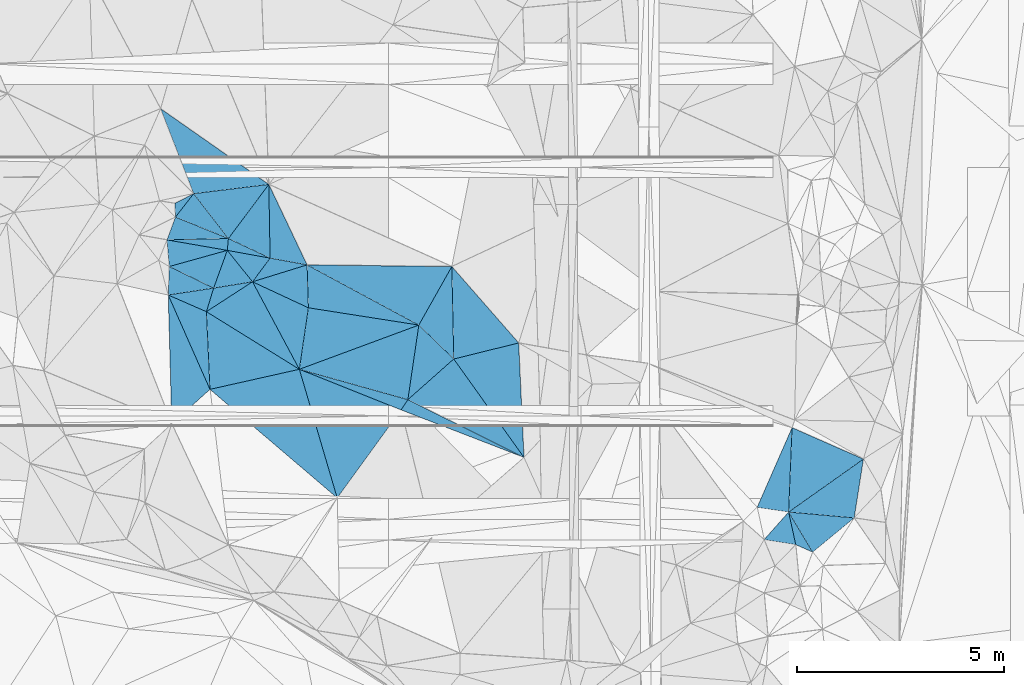
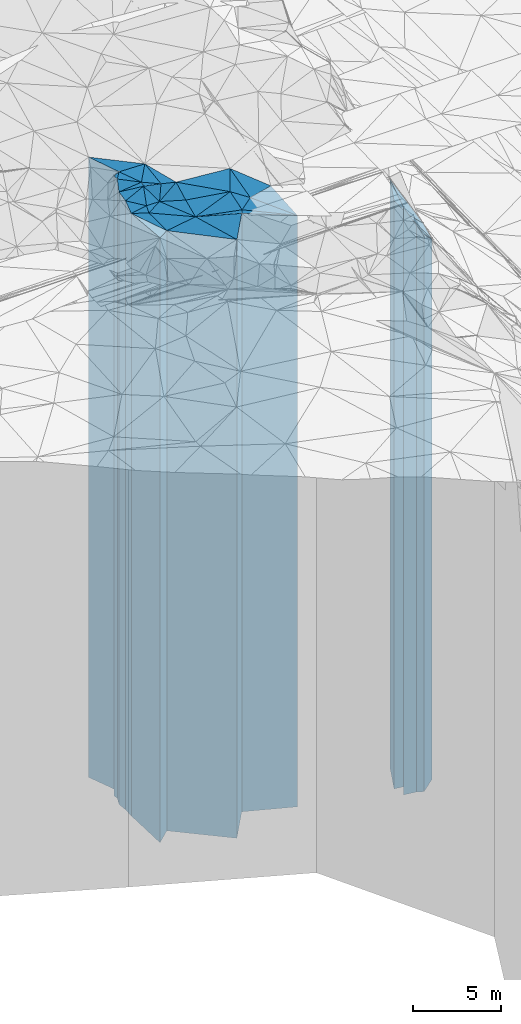
# One storey, part 211 of 275: 42 plates.
"""IFC2X3 building model written with IfcOpenShell, lengths in millimetres."""

from ifc_helpers import new_model, si_unit, frame, origin_with_axes, place, context, subcontext, project, spatial, faceted_brep, material, type_object, element, save


model = new_model("IFC2X3")

# Units and contexts
model_context = context("Model", 3, precision=1e-05, world=origin_with_axes())
body_context = subcontext(model_context, "Body", "Model", "MODEL_VIEW")
ifc_project = project(units=[si_unit("LENGTHUNIT", "METRE", prefix="MILLI"), si_unit("AREAUNIT", "SQUARE_METRE"), si_unit("VOLUMEUNIT", "CUBIC_METRE"), si_unit("MASSUNIT", "GRAM", prefix="KILO"), si_unit("TIMEUNIT", "SECOND"), si_unit("PLANEANGLEUNIT", "RADIAN"), si_unit("SOLIDANGLEUNIT", "STERADIAN"), si_unit("THERMODYNAMICTEMPERATUREUNIT", "DEGREE_CELSIUS"), si_unit("LUMINOUSINTENSITYUNIT", "LUMEN")], contexts=[model_context])

# Site, building, storey
site_placement = place(None, origin_with_axes())
site = spatial("IfcSite", under=ifc_project, at=site_placement, CompositionType="ELEMENT")
building_placement = place(site_placement, origin_with_axes())
building = spatial("IfcBuilding", under=site, at=building_placement, Name="Undefined", CompositionType="ELEMENT")
storey_placement = place(building_placement, origin_with_axes())
storey = spatial("IfcBuildingStorey", under=building, at=storey_placement, Name="Undefined", CompositionType="ELEMENT", Elevation=0.0)

# Plates
ifc_material = material()
plate_type_1 = type_object("IfcPlateType", PredefinedType="NOTDEFINED")
plate_1_placement = place(storey_placement, frame((-114424.275209468, 60931.8089571276, 28524.0), z_axis=(-0.218908902974145, 0.975745300884743, 0.0), x_axis=(0.975745300884743, 0.218908902974141, 0.0)))
element("IfcPlate", 1, at=plate_1_placement, inside=storey, type_object=plate_type_1, material=ifc_material, Name="00", context=body_context, shape_type="Brep", body=[
    faceted_brep([(-5.45696821063757e-12, -20786.0, 0.0), (326.870147705078, -20906.0, 1848.79846191406), (326.870147705078, 20696.0, 1848.79846191406), (0.0, 20696.0, 0.0), (2212.19360351564, -20696.0, 3.82715370506048e-09), (2212.19360351564, 20696.0, 3.82715370506048e-09)], [[[0, 1, 2, 3]], [[1, 4, 5, 2]], [[4, 0, 3, 5]], [[5, 3, 2]], [[4, 1, 0]]]),
])
plate_type_2 = type_object("IfcPlateType", PredefinedType="NOTDEFINED")
plate_2_placement = place(storey_placement, frame((-115431.221927866, 63209.1227928358, 28569.0), z_axis=(0.999623019371744, 0.0274557670102097, 0.0), x_axis=(0.0274557670102113, -0.999623019371743, 0.0)))
element("IfcPlate", 2, at=plate_2_placement, inside=storey, type_object=plate_type_2, material=ifc_material, Name="00", context=body_context, shape_type="Brep", body=[
    faceted_brep([(-1.45519152283669e-11, -20901.0, -1.45519152283669e-11), (2304.10180664061, -20741.0, 944.04174804686), (2304.10180664061, 20741.0, 944.04174804686), (1.45519152283669e-11, 20741.0, -1.45519152283669e-11), (3112.36254882811, -21071.0, -1.28056854009628e-09), (3112.36254882811, 20741.0, -1.28056854009628e-09)], [[[0, 1, 2, 3]], [[1, 4, 5, 2]], [[4, 0, 3, 5]], [[5, 3, 2]], [[4, 1, 0]]]),
])
plate_type_3 = type_object("IfcPlateType", PredefinedType="NOTDEFINED")
plate_3_placement = place(storey_placement, frame((-106841.743380967, 59287.7253005679, 28269.0), z_axis=(-0.814018791273885, -0.580838538195429, 0.0), x_axis=(-0.58083853819543, 0.814018791273885, 0.0)))
element("IfcPlate", 3, at=plate_3_placement, inside=storey, type_object=plate_type_3, material=ifc_material, Name="00", context=body_context, shape_type="Brep", body=[
    faceted_brep([(0.0, -20441.0, 0.0), (2764.37841796875, -20961.0, 1471.83984374999), (2764.37841796875, 20441.0, 1471.83984374999), (2.91038304567337e-11, 20441.0, -1.45519152283669e-11), (2920.22265625, -20821.0, 2.7648638933897e-10), (2920.22265625, 20441.0, 2.7648638933897e-10)], [[[0, 1, 2, 3]], [[1, 4, 5, 2]], [[4, 0, 3, 5]], [[5, 3, 2]], [[4, 1, 0]]]),
])
plate_type_4 = type_object("IfcPlateType", PredefinedType="NOTDEFINED")
plate_4_placement = place(storey_placement, frame((-109645.506137093, 60683.0798817975, 28459.0), z_axis=(-0.663322072844652, 0.748334034824739, 0.0), x_axis=(0.748334034824741, 0.66332207284465, 0.0)))
element("IfcPlate", 4, at=plate_4_placement, inside=storey, type_object=plate_type_4, material=ifc_material, Name="00", context=body_context, shape_type="Brep", body=[
    faceted_brep([(7.27595761418343e-12, -20771.0, 0.0), (1392.30126953125, -20841.0, 1172.17626953125), (1392.30126953125, 20631.0, 1172.17626953125), (7.27595761418343e-12, 20631.0, 0.0), (1480.06762695313, -20631.0, -5.2677933126688e-09), (1480.06762695313, 20631.0, -5.2677933126688e-09)], [[[0, 1, 2, 3]], [[1, 4, 5, 2]], [[4, 0, 3, 5]], [[5, 3, 2]], [[4, 1, 0]]]),
])
plate_type_5 = type_object("IfcPlateType", PredefinedType="NOTDEFINED")
plate_5_placement = place(storey_placement, frame((-111351.75100567, 58310.4171479781, 28519.0), z_axis=(-0.959318896438322, -0.282324733128999, 0.0), x_axis=(-0.282324733128995, 0.959318896438323, 0.0)))
element("IfcPlate", 5, at=plate_5_placement, inside=storey, type_object=plate_type_5, material=ifc_material, Name="00", context=body_context, shape_type="Brep", body=[
    faceted_brep([(0.0, -20691.0, 0.0), (3382.2001953125, -20791.0, 2207.44677734375), (3382.2001953125, 20691.0, 2207.44677734375), (0.0, 20691.0, 0.0), (3237.36010742186, -20701.0, 7.39237293601036e-09), (3237.36010742186, 20691.0, 7.39237293601036e-09)], [[[0, 1, 2, 3]], [[1, 4, 5, 2]], [[4, 0, 3, 5]], [[5, 3, 2]], [[4, 1, 0]]]),
])
plate_type_6 = type_object("IfcPlateType", PredefinedType="NOTDEFINED")
plate_6_placement = place(storey_placement, frame((-108584.435396579, 63896.6649333599, 28459.0), z_axis=(0.871058699947022, -0.491178929970132, 0.0), x_axis=(-0.491178929970129, -0.871058699947024, 0.0)))
element("IfcPlate", 6, at=plate_6_placement, inside=storey, type_object=plate_type_6, material=ifc_material, Name="00", context=body_context, shape_type="Brep", body=[
    faceted_brep([(-1.36424205265939e-11, -21311.0, 1.45519152283669e-11), (1921.20251464842, -20631.0, 1136.74133300783), (1921.20251464842, 20631.0, 1136.74133300783), (7.27595761418343e-12, 20631.0, 0.0), (1622.00488281249, -20841.0, -8.13452061265707e-09), (1622.00488281249, 20631.0, -8.13452061265707e-09)], [[[0, 1, 2, 3]], [[1, 4, 5, 2]], [[4, 0, 3, 5]], [[5, 3, 2]], [[4, 1, 0]]]),
])
plate_type_7 = type_object("IfcPlateType", PredefinedType="NOTDEFINED")
plate_7_placement = place(storey_placement, frame((-112265.737814931, 61416.0778043438, 28509.0), z_axis=(0.370710879079843, 0.928748321200017, 0.0), x_axis=(0.928748321200019, -0.370710879079838, 0.0)))
element("IfcPlate", 7, at=plate_7_placement, inside=storey, type_object=plate_type_7, material=ifc_material, Name="00", context=body_context, shape_type="Brep", body=[
    faceted_brep([(1.45519152283669e-11, -20711.0, 0.0), (2705.26611328124, -20721.0, 290.577789306633), (2705.26611328124, 20681.0, 290.577789306633), (0.0, 20681.0, 0.0), (2644.73071289063, -20681.0, -6.11908035352826e-09), (2644.73071289063, 20681.0, -6.11908035352826e-09)], [[[0, 1, 2, 3]], [[1, 4, 5, 2]], [[4, 0, 3, 5]], [[5, 3, 2]], [[4, 1, 0]]]),
])
plate_type_8 = type_object("IfcPlateType", PredefinedType="NOTDEFINED")
plate_8_placement = place(storey_placement, frame((-115431.221927866, 63209.1227928358, 28629.0), z_axis=(0.399808528152067, 0.916598680348645, 0.0), x_axis=(0.91659867998218, -0.399808528992223, 0.0)))
element("IfcPlate", 8, at=plate_8_placement, inside=storey, type_object=plate_type_8, material=ifc_material, Name="00", context=body_context, shape_type="Brep", body=[
    faceted_brep([(-2.91038304567337e-11, -20841.0, 0.0), (937.52404839384, -20891.0, 591.649108886719), (937.52404839384, 20801.0, 591.649108886719), (-2.91038304567337e-11, 20801.0, 0.0), (1004.98754882813, -20801.0, -5.82076609134674e-11), (1004.98754882813, 20801.0, -5.82076609134674e-11)], [[[0, 1, 2, 3]], [[1, 4, 5, 2]], [[4, 0, 3, 5]], [[5, 3, 2]], [[4, 1, 0]]]),
])
plate_type_9 = type_object("IfcPlateType", PredefinedType="NOTDEFINED")
plate_9_placement = place(storey_placement, frame((-113396.870002641, 63529.141924035, 28609.0), z_axis=(-0.77991973533395, -0.625879546267987, 0.0), x_axis=(-0.625879546267989, 0.779919735333948, 0.0)))
element("IfcPlate", 9, at=plate_9_placement, inside=storey, type_object=plate_type_9, material=ifc_material, Name="00", context=body_context, shape_type="Brep", body=[
    faceted_brep([(0.0, -20781.0, 0.0), (468.398162841782, -20911.0, 827.407470703132), (468.398162841782, 20781.0, 827.407470703132), (0.0, 20781.0, 0.0), (972.676696777358, -21591.0, 1.25874066725373e-09), (972.676696777358, 20781.0, 1.25874066725373e-09)], [[[0, 1, 2, 3]], [[1, 4, 5, 2]], [[4, 0, 3, 5]], [[5, 3, 2]], [[4, 1, 0]]]),
])
plate_type_10 = type_object("IfcPlateType", PredefinedType="NOTDEFINED")
plate_10_placement = place(storey_placement, frame((-108537.92120333, 61664.8413673434, 28459.0), z_axis=(-0.239649905106827, 0.970859373432779, 0.0), x_axis=(0.970859373432779, 0.239649905106829, 0.0)))
element("IfcPlate", 10, at=plate_10_placement, inside=storey, type_object=plate_type_10, material=ifc_material, Name="00", context=body_context, shape_type="Brep", body=[
    faceted_brep([(-1.45519152283669e-11, -20631.0, 1.45519152283669e-11), (489.697570800767, -21311.0, 2177.93383789064), (489.697570800767, 20631.0, 2177.93383789064), (7.27595761418343e-12, 20631.0, 0.0), (1614.46582031249, -20661.0, 1.93540472537279e-09), (1614.46582031249, 20631.0, 1.93540472537279e-09)], [[[0, 1, 2, 3]], [[1, 4, 5, 2]], [[4, 0, 3, 5]], [[5, 3, 2]], [[4, 1, 0]]]),
])
plate_type_11 = type_object("IfcPlateType", PredefinedType="NOTDEFINED")
plate_11_placement = place(storey_placement, frame((-112079.186697475, 63936.8313981279, 28564.0), z_axis=(0.999536862141525, 0.0304312540043118, 0.0), x_axis=(0.0304312540043061, -0.999536862141525, 0.0)))
element("IfcPlate", 11, at=plate_11_placement, inside=storey, type_object=plate_type_11, material=ifc_material, Name="00", context=body_context, shape_type="Brep", body=[
    faceted_brep([(0.0, -21456.0, 0.0), (1534.46032714844, -20736.0, 2652.58959960938), (1534.46032714844, 20736.0, 2652.58959960938), (0.0, 20736.0, 0.0), (1036.19494628906, -20836.0, -1.10594555735588e-09), (1036.19494628906, 20736.0, -1.10594555735588e-09)], [[[0, 1, 2, 3]], [[1, 4, 5, 2]], [[4, 0, 3, 5]], [[5, 3, 2]], [[4, 1, 0]]]),
])
plate_type_12 = type_object("IfcPlateType", PredefinedType="NOTDEFINED")
plate_12_placement = place(storey_placement, frame((-106841.743380967, 59287.7253005679, 28269.0), z_axis=(-0.998916740292856, -0.0465332780136449, 0.0), x_axis=(-0.0465332780136426, 0.998916740292856, 0.0)))
element("IfcPlate", 12, at=plate_12_placement, inside=storey, type_object=plate_type_12, material=ifc_material, Name="00", context=body_context, shape_type="Brep", body=[
    faceted_brep([(0.0, -20441.0, 0.0), (2453.46972656252, -20821.0, 1583.72546386723), (2453.46972656252, 20441.0, 1583.72546386723), (2.91038304567337e-11, 20441.0, -1.45519152283669e-11), (2767.02001953126, -20851.0, -3.08500602841377e-09), (2767.02001953126, 20441.0, -3.08500602841377e-09)], [[[0, 1, 2, 3]], [[1, 4, 5, 2]], [[4, 0, 3, 5]], [[5, 3, 2]], [[4, 1, 0]]]),
])
plate_type_13 = type_object("IfcPlateType", PredefinedType="NOTDEFINED")
plate_13_placement = place(storey_placement, frame((-112079.186697475, 63936.8313981279, 28609.0), z_axis=(-0.179873679992064, -0.983689716956578, 0.0), x_axis=(-0.983689716956578, 0.179873679992061, 0.0)))
element("IfcPlate", 13, at=plate_13_placement, inside=storey, type_object=plate_type_13, material=ifc_material, Name="00", context=body_context, shape_type="Brep", body=[
    faceted_brep([(0.0, -21411.0, -7.27595761418343e-12), (1222.85888671875, -20781.0, 638.056518554695), (1222.85888671875, 20781.0, 638.056518554695), (0.0, 20781.0, 0.0), (906.972961425781, -21511.0, 2.75758793577552e-09), (906.972961425781, 20781.0, 2.75758793577552e-09)], [[[0, 1, 2, 3]], [[1, 4, 5, 2]], [[4, 0, 3, 5]], [[5, 3, 2]], [[4, 1, 0]]]),
])
plate_type_14 = type_object("IfcPlateType", PredefinedType="NOTDEFINED")
plate_14_placement = place(storey_placement, frame((-114335.34226821, 63376.597482125, 28609.0), z_axis=(0.955992514125044, -0.293391058038377, 0.0), x_axis=(-0.293391058038374, -0.955992514125045, 0.0)))
element("IfcPlate", 14, at=plate_14_placement, inside=storey, type_object=plate_type_14, material=ifc_material, Name="00", context=body_context, shape_type="Brep", body=[
    faceted_brep([(-7.27595761418343e-12, -20911.0, 0.0), (-421.170715332039, -20781.0, 852.417297363267), (-421.170715332039, 20781.0, 852.417297363267), (0.0, 20781.0, 0.0), (595.482971191406, -20821.0, -5.82076609134674e-10), (595.482971191406, 20781.0, -5.82076609134674e-10)], [[[0, 1, 2, 3]], [[1, 4, 5, 2]], [[4, 0, 3, 5]], [[5, 3, 2]], [[4, 1, 0]]]),
])
plate_type_15 = type_object("IfcPlateType", PredefinedType="NOTDEFINED")
plate_15_placement = place(storey_placement, frame((-113978.705792529, 64573.0131390828, 28994.0), z_axis=(-0.37506133888815, -0.926999995723532, 0.0), x_axis=(-0.926999995723534, 0.375061338888145, 0.0)))
element("IfcPlate", 15, at=plate_15_placement, inside=storey, type_object=plate_type_15, material=ifc_material, Name="00", context=body_context, shape_type="Brep", body=[
    faceted_brep([(1.45519152283669e-11, -21306.0, 3.63797880709171e-12), (1362.92297363281, -21166.0, 586.720397949215), (1362.92297363281, 21166.0, 586.720397949215), (1.45519152283669e-11, 21166.0, 3.63797880709171e-12), (1379.02136230469, -21656.0, 3.78713593818247e-09), (1379.02136230469, 21166.0, 3.78713593818247e-09)], [[[0, 1, 2, 3]], [[1, 4, 5, 2]], [[4, 0, 3, 5]], [[5, 3, 2]], [[4, 1, 0]]]),
])
plate_type_16 = type_object("IfcPlateType", PredefinedType="NOTDEFINED")
plate_16_placement = place(storey_placement, frame((-113396.870002641, 63529.141924035, 28609.0), z_axis=(-0.801762383782183, 0.597642936837633, 0.0), x_axis=(0.597642936837635, 0.801762383782182, 0.0)))
element("IfcPlate", 16, at=plate_16_placement, inside=storey, type_object=plate_type_16, material=ifc_material, Name="00", context=body_context, shape_type="Brep", body=[
    faceted_brep([(0.0, -20781.0, 0.0), (244.392623901374, -21591.0, 941.473449707031), (244.392623901374, 20781.0, 941.473449707031), (0.0, 20781.0, 0.0), (711.969116210945, -21511.0, 2.91038304567337e-10), (711.969116210945, 20781.0, 2.91038304567337e-10)], [[[0, 1, 2, 3]], [[1, 4, 5, 2]], [[4, 0, 3, 5]], [[5, 3, 2]], [[4, 1, 0]]]),
])
plate_type_17 = type_object("IfcPlateType", PredefinedType="NOTDEFINED")
plate_17_placement = place(storey_placement, frame((-114005.648466183, 64287.7516934994, 28974.0), z_axis=(0.178635415008195, 0.983915336045155, 0.0), x_axis=(0.983915336045154, -0.178635415008198, 0.0)))
element("IfcPlate", 17, at=plate_17_placement, inside=storey, type_object=plate_type_17, material=ifc_material, Name="00", context=body_context, shape_type="Brep", body=[
    faceted_brep([(1.45519152283669e-11, -21226.0, 1.45519152283669e-11), (-24.4484863281104, -21326.0, 285.486022949219), (-24.4484863281104, 21146.0, 285.486022949219), (1.45519152283669e-11, 21146.0, 1.45519152283669e-11), (1051.18981933595, -21146.0, 4.80213202536106e-10), (1051.18981933595, 21146.0, 4.80213202536106e-10)], [[[0, 1, 2, 3]], [[1, 4, 5, 2]], [[4, 0, 3, 5]], [[5, 3, 2]], [[4, 1, 0]]]),
])
plate_type_18 = type_object("IfcPlateType", PredefinedType="NOTDEFINED")
plate_18_placement = place(storey_placement, frame((-113396.870002641, 63529.141924035, 28609.0), z_axis=(0.421997696830674, 0.90659690263623, 0.0), x_axis=(0.906596902636231, -0.421997696830672, 0.0)))
element("IfcPlate", 18, at=plate_18_placement, inside=storey, type_object=plate_type_18, material=ifc_material, Name="00", context=body_context, shape_type="Brep", body=[
    faceted_brep([(0.0, -20781.0, 0.0), (1022.56359863278, -21411.0, 925.669311523438), (1022.56359863278, 20781.0, 925.669311523438), (0.0, 20781.0, 0.0), (1488.22045898436, -20791.0, 5.3114490583539e-10), (1488.22045898436, 20781.0, 5.3114490583539e-10)], [[[0, 1, 2, 3]], [[1, 4, 5, 2]], [[4, 0, 3, 5]], [[5, 3, 2]], [[4, 1, 0]]]),
])
plate_type_19 = type_object("IfcPlateType", PredefinedType="NOTDEFINED")
plate_19_placement = place(storey_placement, frame((-113003.513715425, 65878.9229417701, 28974.0), z_axis=(0.80124705457327, -0.598333650681339, 0.0), x_axis=(-0.59833365068134, -0.80124705457327, 0.0)))
element("IfcPlate", 19, at=plate_19_placement, inside=storey, type_object=plate_type_19, material=ifc_material, Name="00", context=body_context, shape_type="Brep", body=[
    faceted_brep([(0.0, -21456.0, 0.0), (1406.14453125, -21146.0, 1090.1639404297), (1406.14453125, 21146.0, 1090.1639404297), (1.45519152283669e-11, 21146.0, 1.45519152283669e-11), (1629.84655761718, -21326.0, -3.75439412891865e-09), (1629.84655761718, 21146.0, -3.75439412891865e-09)], [[[0, 1, 2, 3]], [[1, 4, 5, 2]], [[4, 0, 3, 5]], [[5, 3, 2]], [[4, 1, 0]]]),
])
plate_type_20 = type_object("IfcPlateType", PredefinedType="NOTDEFINED")
plate_20_placement = place(storey_placement, frame((-112265.737814931, 61416.0778043438, 28524.0), z_axis=(-0.989388287916001, 0.145295614987667, 0.0), x_axis=(0.145295614987661, 0.989388287916002, 0.0)))
element("IfcPlate", 20, at=plate_20_placement, inside=storey, type_object=plate_type_20, material=ifc_material, Name="00", context=body_context, shape_type="Brep", body=[
    faceted_brep([(0.0, -20696.0, 0.0), (1926.29235839843, -20866.0, 1426.14794921874), (1926.29235839843, 20696.0, 1426.14794921874), (0.0, 20696.0, 0.0), (1500.96630859374, -20876.0, -1.01863406598568e-09), (1500.96630859374, 20696.0, -1.01863406598568e-09)], [[[0, 1, 2, 3]], [[1, 4, 5, 2]], [[4, 0, 3, 5]], [[5, 3, 2]], [[4, 1, 0]]]),
])
plate_type_21 = type_object("IfcPlateType", PredefinedType="NOTDEFINED")
plate_21_placement = place(storey_placement, frame((-109381.130042995, 62483.8034255069, 28564.0), z_axis=(-0.871058699947022, 0.491178929970132, 0.0), x_axis=(0.491178929970125, 0.871058699947026, 0.0)))
element("IfcPlate", 21, at=plate_21_placement, inside=storey, type_object=plate_type_21, material=ifc_material, Name="00", context=body_context, shape_type="Brep", body=[
    faceted_brep([(7.27595761418343e-12, -20736.0, 0.0), (-59.5559234619359, -21456.0, 3063.86254882813), (-59.5559234619359, 20736.0, 3063.86254882813), (0.0, 20736.0, 0.0), (1622.0048828125, -21206.0, -8.14907252788544e-09), (1622.0048828125, 20736.0, -8.14907252788544e-09)], [[[0, 1, 2, 3]], [[1, 4, 5, 2]], [[4, 0, 3, 5]], [[5, 3, 2]], [[4, 1, 0]]]),
])
plate_type_22 = type_object("IfcPlateType", PredefinedType="NOTDEFINED")
plate_22_placement = place(storey_placement, frame((-114818.365511907, 65655.9589159586, 29064.0), z_axis=(0.790243382500429, -0.612793110612612, 0.0), x_axis=(-0.612793110612607, -0.790243382500433, 0.0)))
element("IfcPlate", 22, at=plate_22_placement, inside=storey, type_object=plate_type_22, material=ifc_material, Name="00", context=body_context, shape_type="Brep", body=[
    faceted_brep([(-1.45519152283669e-11, -21586.0, -2.91038304567337e-11), (341.253051757791, -21236.0, 1327.15722656247), (341.253051757791, 21236.0, 1327.15722656247), (-1.45519152283669e-11, 21236.0, -2.91038304567337e-11), (715.891052246094, -21586.0, 3.98722477257252e-09), (715.891052246094, 21236.0, 3.98722477257252e-09)], [[[0, 1, 2, 3]], [[1, 4, 5, 2]], [[4, 0, 3, 5]], [[5, 3, 2]], [[4, 1, 0]]]),
])
plate_type_23 = type_object("IfcPlateType", PredefinedType="NOTDEFINED")
plate_23_placement = place(storey_placement, frame((-114335.34226821, 63376.597482125, 28674.0), z_axis=(-0.940334168914727, 0.340252333969144, 0.0), x_axis=(0.340252333969139, 0.940334168914729, 0.0)))
element("IfcPlate", 23, at=plate_23_placement, inside=storey, type_object=plate_type_23, material=ifc_material, Name="00", context=body_context, shape_type="Brep", body=[
    faceted_brep([(1.45519152283669e-11, -20846.0, 0.0), (124.9782562256, -21246.0, 1185.48742675781), (124.9782562256, 20846.0, 1185.48742675781), (1.45519152283669e-11, 20846.0, 0.0), (968.96850585939, -21526.0, 3.20142135024071e-10), (968.96850585939, 20846.0, 3.20142135024071e-10)], [[[0, 1, 2, 3]], [[1, 4, 5, 2]], [[4, 0, 3, 5]], [[5, 3, 2]], [[4, 1, 0]]]),
])
plate_type_24 = type_object("IfcPlateType", PredefinedType="NOTDEFINED")
plate_24_placement = place(storey_placement, frame((-115272.671397313, 65422.2793009168, 29239.0), z_axis=(0.998896409609664, 0.0469676789816477, 0.0), x_axis=(0.0469676789816322, -0.998896409609664, 0.0)))
element("IfcPlate", 24, at=plate_24_placement, inside=storey, type_object=plate_type_24, material=ifc_material, Name="00", context=body_context, shape_type="Brep", body=[
    faceted_brep([(0.0, -21441.0, -1.45519152283669e-11), (-212.084030151367, -21411.0, 464.779907226548), (-212.084030151367, 21411.0, 464.779907226548), (0.0, 21411.0, -1.45519152283669e-11), (332.415405273438, -21411.0, 2.91038304567337e-11), (332.415405273438, 21411.0, 2.91038304567337e-11)], [[[0, 1, 2, 3]], [[1, 4, 5, 2]], [[4, 0, 3, 5]], [[5, 3, 2]], [[4, 1, 0]]]),
])
plate_type_25 = type_object("IfcPlateType", PredefinedType="NOTDEFINED")
plate_25_placement = place(storey_placement, frame((-115616.578924319, 67708.4830566807, 29129.0), z_axis=(0.93200320198404, 0.362450039993786, 0.0), x_axis=(0.362450039993793, -0.932003201984037, 0.0)))
element("IfcPlate", 25, at=plate_25_placement, inside=storey, type_object=plate_type_25, material=ifc_material, Name="00", context=body_context, shape_type="Brep", body=[
    faceted_brep([(0.0, -21571.0, 0.0), (2652.26147460936, -21301.0, 1772.26098632811), (2652.26147460936, 21301.0, 1772.26098632811), (1.45519152283669e-11, 21301.0, 0.0), (2202.271484375, -21521.0, 3.57977114617825e-09), (2202.271484375, 21301.0, 3.57977114617825e-09)], [[[0, 1, 2, 3]], [[1, 4, 5, 2]], [[4, 0, 3, 5]], [[5, 3, 2]], [[4, 1, 0]]]),
])
plate_type_26 = type_object("IfcPlateType", PredefinedType="NOTDEFINED")
plate_26_placement = place(storey_placement, frame((-101212.923146997, 58080.9184503828, 27609.0), z_axis=(0.145895997045634, 0.989299933309439, 0.0), x_axis=(0.989299933309439, -0.145895997045635, 0.0)))
element("IfcPlate", 26, at=plate_26_placement, inside=storey, type_object=plate_type_26, material=ifc_material, Name="00", context=body_context, shape_type="Brep", body=[
    faceted_brep([(3.63797880709171e-12, -20881.0, 0.0), (553.412109374985, -20891.0, 2027.96325683594), (553.412109374985, 19781.0, 2027.96325683594), (0.0, 19781.0, 0.0), (768.505065917954, -19781.0, 2.48837750405073e-09), (768.505065917954, 19781.0, 2.48837750405073e-09)], [[[0, 1, 2, 3]], [[1, 4, 5, 2]], [[4, 0, 3, 5]], [[5, 3, 2]], [[4, 1, 0]]]),
])
plate_type_27 = type_object("IfcPlateType", PredefinedType="NOTDEFINED")
plate_27_placement = place(storey_placement, frame((-98645.928522441, 59248.7534547814, 26574.0), z_axis=(-0.402422698190268, -0.915453970432847, 0.0), x_axis=(-0.915453970432845, 0.402422698190272, 0.0)))
element("IfcPlate", 27, at=plate_27_placement, inside=storey, type_object=plate_type_27, material=ifc_material, Name="00", context=body_context, shape_type="Brep", body=[
    faceted_brep([(0.0, -18746.0, -1.81898940354586e-12), (1138.87854003908, -20816.0, 1898.80371093751), (1138.87854003908, 18746.0, 1898.80371093751), (3.63797880709171e-12, 18746.0, -1.45519152283669e-11), (1882.81701660156, -21926.0, 6.88851287122816e-09), (1882.81701660156, 18746.0, 6.88851287122816e-09)], [[[0, 1, 2, 3]], [[1, 4, 5, 2]], [[4, 0, 3, 5]], [[5, 3, 2]], [[4, 1, 0]]]),
])
plate_type_28 = type_object("IfcPlateType", PredefinedType="NOTDEFINED")
plate_28_placement = place(storey_placement, frame((-100452.641159948, 57968.796640872, 26484.0), z_axis=(0.0894377199785231, 0.995992416760812, 0.0), x_axis=(0.995992416760812, -0.0894377199785211, 0.0)))
element("IfcPlate", 28, at=plate_28_placement, inside=storey, type_object=plate_type_28, material=ifc_material, Name="00", context=body_context, shape_type="Brep", body=[
    faceted_brep([(0.0, -20906.0, 2.91038304567337e-11), (1684.99560546875, -18836.0, 1436.41552734375), (1684.99560546875, 18656.0, 1436.41552734375), (0.0, 18656.0, 7.27595761418343e-12), (1589.02490234376, -18656.0, 2.21189111471176e-09), (1589.02490234376, 18656.0, 2.21189111471176e-09)], [[[0, 1, 2, 3]], [[1, 4, 5, 2]], [[4, 0, 3, 5]], [[5, 3, 2]], [[4, 1, 0]]]),
])
plate_type_29 = type_object("IfcPlateType", PredefinedType="NOTDEFINED")
plate_29_placement = place(storey_placement, frame((-113978.705792529, 64573.0131390828, 29064.0), z_axis=(-0.80124705457327, 0.598333650681339, 0.0), x_axis=(0.598333650681336, 0.801247054573272, 0.0)))
element("IfcPlate", 29, at=plate_29_placement, inside=storey, type_object=plate_type_29, material=ifc_material, Name="00", context=body_context, shape_type="Brep", body=[
    faceted_brep([(0.0, -21236.0, 1.45519152283669e-11), (365.310455322273, -21586.0, 1320.73779296878), (365.310455322273, 21236.0, 1320.73779296878), (-1.45519152283669e-11, 21236.0, -2.91038304567337e-11), (1629.8465576172, -21366.0, 3.33238858729601e-09), (1629.8465576172, 21236.0, 3.33238858729601e-09)], [[[0, 1, 2, 3]], [[1, 4, 5, 2]], [[4, 0, 3, 5]], [[5, 3, 2]], [[4, 1, 0]]]),
])
plate_type_30 = type_object("IfcPlateType", PredefinedType="NOTDEFINED")
plate_30_placement = place(storey_placement, frame((-112971.366698745, 64099.9719673701, 28924.0), z_axis=(0.179873679992064, 0.983689716956578, 0.0), x_axis=(0.983689716956578, -0.179873679992061, 0.0)))
element("IfcPlate", 30, at=plate_30_placement, inside=storey, type_object=plate_type_30, material=ifc_material, Name="00", context=body_context, shape_type="Brep", body=[
    faceted_brep([(0.0, -21196.0, -7.27595761418343e-12), (-351.609161376968, -21506.0, 1744.1533203125), (-351.609161376968, 21096.0, 1744.1533203125), (0.0, 21096.0, 0.0), (906.972961425781, -21096.0, 2.75031197816134e-09), (906.972961425781, 21096.0, 2.75031197816134e-09)], [[[0, 1, 2, 3]], [[1, 4, 5, 2]], [[4, 0, 3, 5]], [[5, 3, 2]], [[4, 1, 0]]]),
])
plate_type_31 = type_object("IfcPlateType", PredefinedType="NOTDEFINED")
plate_31_placement = place(storey_placement, frame((-98869.9844511925, 57826.6778798589, 26484.0), z_axis=(-0.0894377199785231, -0.995992416760812, 0.0), x_axis=(-0.995992416760812, 0.0894377199785203, 0.0)))
element("IfcPlate", 31, at=plate_31_placement, inside=storey, type_object=plate_type_31, material=ifc_material, Name="00", context=body_context, shape_type="Brep", body=[
    faceted_brep([(2.91038304567337e-11, -18656.0, 0.0), (923.837036132842, -19846.0, 911.880004882813), (923.837036132842, 18656.0, 911.880004882813), (0.0, 18656.0, 7.27595761418343e-12), (1589.02490234378, -20906.0, 2.21189111471176e-09), (1589.02490234376, 18656.0, 2.21189111471176e-09)], [[[0, 1, 2, 3]], [[1, 4, 5, 2]], [[4, 0, 3, 5]], [[5, 3, 2]], [[4, 1, 0]]]),
])
plate_type_32 = type_object("IfcPlateType", PredefinedType="NOTDEFINED")
plate_32_placement = place(storey_placement, frame((-112265.737814931, 61416.0778043438, 28509.0), z_axis=(0.959318896438322, 0.282324733128999, 0.0), x_axis=(0.282324733128997, -0.959318896438322, 0.0)))
element("IfcPlate", 32, at=plate_32_placement, inside=storey, type_object=plate_type_32, material=ifc_material, Name="00", context=body_context, shape_type="Brep", body=[
    faceted_brep([(1.45519152283669e-11, -20711.0, 0.0), (1634.01660156249, -20681.0, 2079.56469726563), (1634.01660156249, 20681.0, 2079.56469726563), (0.0, 20681.0, 0.0), (3237.36010742186, -20701.0, 7.39237293601036e-09), (3237.36010742186, 20681.0, 7.40692485123873e-09)], [[[0, 1, 2, 3]], [[1, 4, 5, 2]], [[4, 0, 3, 5]], [[5, 3, 2]], [[4, 1, 0]]]),
])
plate_type_33 = type_object("IfcPlateType", PredefinedType="NOTDEFINED")
plate_33_placement = place(storey_placement, frame((-114335.34226821, 63376.597482125, 28649.0), z_axis=(-0.436964148096435, -0.899478923198513, 0.0), x_axis=(-0.899478923198528, 0.436964148096405, 0.0)))
element("IfcPlate", 33, at=plate_33_placement, inside=storey, type_object=plate_type_33, material=ifc_material, Name="00", context=body_context, shape_type="Brep", body=[
    faceted_brep([(0.0, -20871.0, -1.00044417195022e-11), (912.540222167969, -20821.0, 629.500061035139), (912.540222167969, 20821.0, 629.500061035139), (0.0, 20821.0, 7.27595761418343e-12), (1192.05700683594, -21271.0, -6.36191543890163e-09), (1192.05700683594, 20821.0, -6.36191543890163e-09)], [[[0, 1, 2, 3]], [[1, 4, 5, 2]], [[4, 0, 3, 5]], [[5, 3, 2]], [[4, 1, 0]]]),
])
plate_type_34 = type_object("IfcPlateType", PredefinedType="NOTDEFINED")
plate_34_placement = place(storey_placement, frame((-101043.827473649, 57302.8396283763, 27414.0), z_axis=(0.156699567990622, 0.98764631594086, 0.0), x_axis=(0.98764631594086, -0.156699567990618, 0.0)))
element("IfcPlate", 34, at=plate_34_placement, inside=storey, type_object=plate_type_34, material=ifc_material, Name="00", context=body_context, shape_type="Brep", body=[
    faceted_brep([(0.0, -21016.0, -7.27595761418343e-12), (479.527801513686, -19976.0, 750.368652343743), (479.527801513686, 19586.0, 750.368652343743), (-7.27595761418343e-12, 19586.0, 0.0), (773.886291503921, -19586.0, 1.16415321826935e-09), (773.886291503921, 19586.0, 1.16415321826935e-09)], [[[0, 1, 2, 3]], [[1, 4, 5, 2]], [[4, 0, 3, 5]], [[5, 3, 2]], [[4, 1, 0]]]),
])
plate_type_35 = type_object("IfcPlateType", PredefinedType="NOTDEFINED")
plate_35_placement = place(storey_placement, frame((-100279.501523875, 57181.5719801679, 27079.0), z_axis=(0.404710884868236, 0.914444694702293, 0.0), x_axis=(0.914444694702291, -0.404710884868239, 0.0)))
element("IfcPlate", 35, at=plate_35_placement, inside=storey, type_object=plate_type_35, material=ifc_material, Name="00", context=body_context, shape_type="Brep", body=[
    faceted_brep([(-1.45519152283669e-11, -19921.0, 1.81898940354586e-12), (-476.925018310547, -20311.0, 649.801940917978), (-476.925018310547, 19251.0, 649.801940917978), (0.0, 19251.0, 1.45519152283669e-11), (445.982055664033, -19251.0, -2.6102497940883e-09), (445.982055664033, 19251.0, -2.6102497940883e-09)], [[[0, 1, 2, 3]], [[1, 4, 5, 2]], [[4, 0, 3, 5]], [[5, 3, 2]], [[4, 1, 0]]]),
])
plate_type_36 = type_object("IfcPlateType", PredefinedType="NOTDEFINED")
plate_36_placement = place(storey_placement, frame((-114424.275209468, 60931.8089571276, 28569.0), z_axis=(-0.998955794192235, -0.0456872110087889, 0.0), x_axis=(-0.0456872110087934, 0.998955794192235, 0.0)))
element("IfcPlate", 36, at=plate_36_placement, inside=storey, type_object=plate_type_36, material=ifc_material, Name="00", context=body_context, shape_type="Brep", body=[
    faceted_brep([(1.45519152283669e-11, -20741.0, -1.45519152283669e-11), (2320.9404296875, -20901.0, 901.851135253906), (2320.9404296875, 20741.0, 901.851135253906), (1.45519152283669e-11, 20741.0, -1.45519152283669e-11), (1877.47167968751, -20861.0, -3.66708263754845e-09), (1877.47167968751, 20741.0, -3.66708263754845e-09)], [[[0, 1, 2, 3]], [[1, 4, 5, 2]], [[4, 0, 3, 5]], [[5, 3, 2]], [[4, 1, 0]]]),
])
plate_type_37 = type_object("IfcPlateType", PredefinedType="NOTDEFINED")
plate_37_placement = place(storey_placement, frame((-115407.572455855, 63897.4836738231, 28874.0), z_axis=(-0.26818269195118, 0.963368072824618, 0.0), x_axis=(0.963368072824619, 0.268182691951178, 0.0)))
element("IfcPlate", 37, at=plate_37_placement, inside=storey, type_object=plate_type_37, material=ifc_material, Name="00", context=body_context, shape_type="Brep", body=[
    faceted_brep([(-1.45519152283669e-11, -21046.0, 0.0), (119.774719238267, -21286.0, 633.919555664063), (119.774719238267, 21046.0, 633.919555664063), (3.63797880709171e-12, 21046.0, 0.0), (1455.23193359374, -21326.0, 2.38651409745216e-09), (1455.23193359374, 21046.0, 2.38651409745216e-09)], [[[0, 1, 2, 3]], [[1, 4, 5, 2]], [[4, 0, 3, 5]], [[5, 3, 2]], [[4, 1, 0]]]),
])
plate_type_38 = type_object("IfcPlateType", PredefinedType="NOTDEFINED")
plate_38_placement = place(storey_placement, frame((-109381.130042995, 62483.8034255069, 28524.0), z_axis=(-0.154618675002231, -0.987974223014221, 0.0), x_axis=(-0.987974223014222, 0.154618675002225, 0.0)))
element("IfcPlate", 38, at=plate_38_placement, inside=storey, type_object=plate_type_38, material=ifc_material, Name="00", context=body_context, shape_type="Brep", body=[
    faceted_brep([(-2.18278728425503e-11, -20776.0, 0.0), (2684.82788085938, -20696.0, 1500.89965820312), (2684.82788085938, 20696.0, 1500.89965820312), (0.0, 20696.0, 0.0), (2698.9812011719, -20876.0, -8.67294147610664e-09), (2698.9812011719, 20696.0, -8.67294147610664e-09)], [[[0, 1, 2, 3]], [[1, 4, 5, 2]], [[4, 0, 3, 5]], [[5, 3, 2]], [[4, 1, 0]]]),
])
plate_type_39 = type_object("IfcPlateType", PredefinedType="NOTDEFINED")
plate_39_placement = place(storey_placement, frame((-113396.870002641, 63529.141924035, 28524.0), z_axis=(0.544062688997716, -0.839044569996478, 0.0), x_axis=(-0.839044569996479, -0.544062688997715, 0.0)))
element("IfcPlate", 39, at=plate_39_placement, inside=storey, type_object=plate_type_39, material=ifc_material, Name="00", context=body_context, shape_type="Brep", body=[
    faceted_brep([(0.0, -20866.0, 0.0), (200.569030761719, -20696.0, 2388.36181640626), (200.569030761719, 20696.0, 2388.36181640626), (0.0, 20696.0, 0.0), (1326.72534179689, -20906.0, -2.57568899542093e-09), (1326.72534179689, 20696.0, -2.57568899542093e-09)], [[[0, 1, 2, 3]], [[1, 4, 5, 2]], [[4, 0, 3, 5]], [[5, 3, 2]], [[4, 1, 0]]]),
])
plate_type_40 = type_object("IfcPlateType", PredefinedType="NOTDEFINED")
plate_40_placement = place(storey_placement, frame((-106841.743380967, 59287.7253005679, 28269.0), z_axis=(-0.445545580153449, -0.89525925630832, 0.0), x_axis=(-0.895259256308323, 0.445545580153443, 0.0)))
element("IfcPlate", 40, at=plate_40_placement, inside=storey, type_object=plate_type_40, material=ifc_material, Name="00", context=body_context, shape_type="Brep", body=[
    faceted_brep([(0.0, -20441.0, 0.0), (3168.31738281251, -20921.0, 294.560119628918), (3168.31738281251, 20441.0, 294.560119628918), (2.91038304567337e-11, 20441.0, -1.45519152283669e-11), (3131.78857421878, -20961.0, -6.44922693027183e-09), (3131.78857421878, 20441.0, -6.44922693027183e-09)], [[[0, 1, 2, 3]], [[1, 4, 5, 2]], [[4, 0, 3, 5]], [[5, 3, 2]], [[4, 1, 0]]]),
])
plate_type_41 = type_object("IfcPlateType", PredefinedType="NOTDEFINED")
plate_41_placement = place(storey_placement, frame((-115462.191569399, 64540.3030515924, 28994.0), z_axis=(0.170841814937065, 0.985298469636998, 0.0), x_axis=(0.985298469637004, -0.17084181493703, 0.0)))
element("IfcPlate", 41, at=plate_41_placement, inside=storey, type_object=plate_type_41, material=ifc_material, Name="00", context=body_context, shape_type="Brep", body=[
    faceted_brep([(1.45519152283669e-11, -21166.0, 0.0), (1456.0880126953, -21306.0, 285.670593261711), (1456.0880126953, 21166.0, 285.670593261711), (1.45519152283669e-11, 21166.0, 3.63797880709171e-12), (1478.27600097655, -21206.0, -5.63886715099216e-09), (1478.27600097655, 21166.0, -5.63886715099216e-09)], [[[0, 1, 2, 3]], [[1, 4, 5, 2]], [[4, 0, 3, 5]], [[5, 3, 2]], [[4, 1, 0]]]),
])
plate_type_42 = type_object("IfcPlateType", PredefinedType="NOTDEFINED")
plate_42_placement = place(storey_placement, frame((-109645.506137093, 60683.0798817975, 28524.0), z_axis=(-0.989393605851093, 0.14525939797814, 0.0), x_axis=(0.14525939797814, 0.989393605851093, 0.0)))
element("IfcPlate", 42, at=plate_42_placement, inside=storey, type_object=plate_type_42, material=ifc_material, Name="00", context=body_context, shape_type="Brep", body=[
    faceted_brep([(-7.27595761418343e-12, -20706.0, -1.45519152283669e-11), (344.610168457024, -20696.0, 2698.91528320313), (344.610168457024, 20696.0, 2698.91528320313), (0.0, 20696.0, 0.0), (1820.02746582031, -20776.0, -4.04543243348598e-09), (1820.02746582031, 20696.0, -4.04543243348598e-09)], [[[0, 1, 2, 3]], [[1, 4, 5, 2]], [[4, 0, 3, 5]], [[5, 3, 2]], [[4, 1, 0]]]),
])

save(model, "model.ifc")
